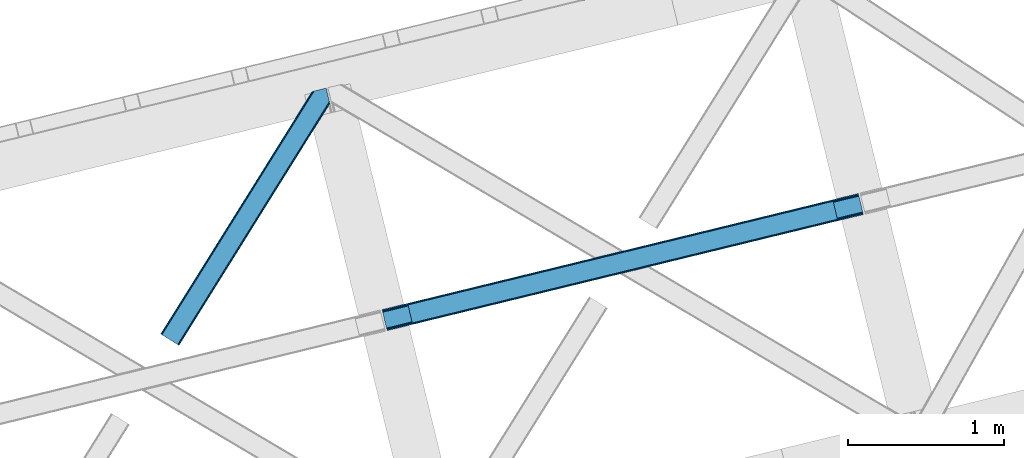
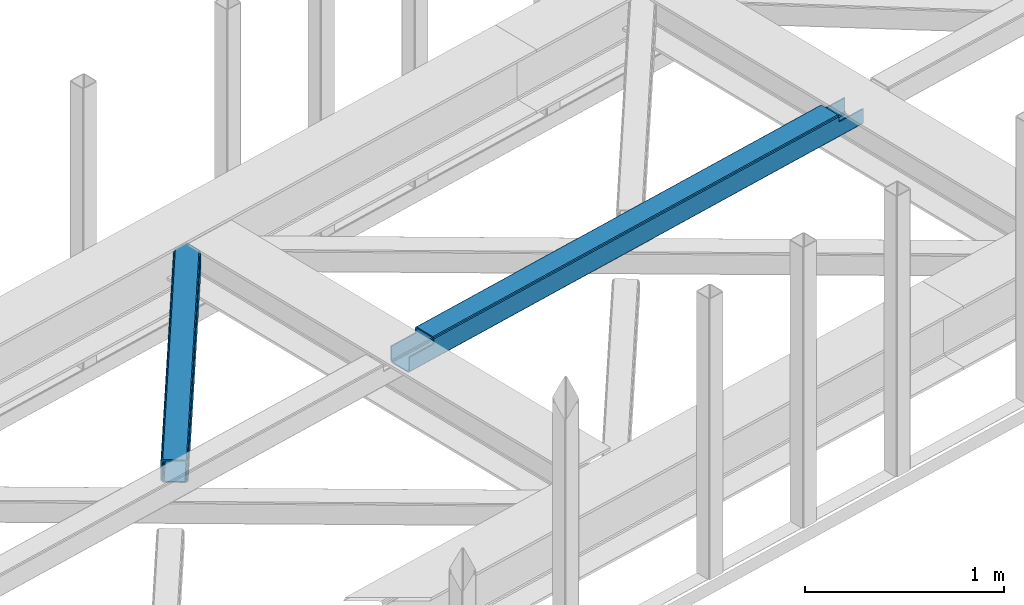
# One storey, part 51 of 66: 1 beam, 1 member.
"""IFC4 building model written with IfcOpenShell, lengths in millimetres."""

from ifc_helpers import new_model, entity, si_unit, converted_unit, derived_unit, direction, frame, origin, place, context, subcontext, project, spatial, triangles, polygons, material, type_object, element, save


model = new_model("IFC4")

# Units and contexts
model_context = context("Model", 3, precision=0.01, world=origin(), true_north=direction((6.12303176911189e-17, 1.0)))
plan_context = context("Plan", 3, precision=0.01, world=origin(), true_north=direction((6.12303176911189e-17, 1.0)))
body_context = subcontext(model_context, "Body", "Model", "MODEL_VIEW")
ifc_project = project(units=[si_unit("LENGTHUNIT", "METRE", prefix="MILLI"), si_unit("AREAUNIT", "SQUARE_METRE"), si_unit("VOLUMEUNIT", "CUBIC_METRE"), converted_unit("PLANEANGLEUNIT", "DEGREE", entity("IfcRatioMeasure", 0.0174532925199433), si_unit("PLANEANGLEUNIT", "RADIAN"), dimensions=[0, 0, 0, 0, 0, 0, 0]), si_unit("MASSUNIT", "GRAM", prefix="KILO"), derived_unit("MASSDENSITYUNIT", [(si_unit("MASSUNIT", "GRAM", prefix="KILO"), 1), (si_unit("LENGTHUNIT", "METRE"), -3)]), derived_unit("MOMENTOFINERTIAUNIT", [(si_unit("LENGTHUNIT", "METRE"), 4)]), si_unit("TIMEUNIT", "SECOND"), si_unit("FREQUENCYUNIT", "HERTZ"), si_unit("THERMODYNAMICTEMPERATUREUNIT", "DEGREE_CELSIUS"), derived_unit("THERMALTRANSMITTANCEUNIT", [(si_unit("MASSUNIT", "GRAM", prefix="KILO"), 1), (si_unit("THERMODYNAMICTEMPERATUREUNIT", "KELVIN"), -1), (si_unit("TIMEUNIT", "SECOND"), -3)]), derived_unit("VOLUMETRICFLOWRATEUNIT", [(si_unit("LENGTHUNIT", "METRE"), 3), (si_unit("TIMEUNIT", "SECOND"), -1)]), derived_unit("MASSFLOWRATEUNIT", [(si_unit("MASSUNIT", "GRAM", prefix="KILO"), 1), (si_unit("TIMEUNIT", "SECOND"), -1)]), derived_unit("ROTATIONALFREQUENCYUNIT", [(si_unit("TIMEUNIT", "SECOND"), -1)]), si_unit("ELECTRICCURRENTUNIT", "AMPERE"), si_unit("ELECTRICVOLTAGEUNIT", "VOLT"), si_unit("POWERUNIT", "WATT"), si_unit("FORCEUNIT", "NEWTON", prefix="KILO"), si_unit("ILLUMINANCEUNIT", "LUX"), si_unit("LUMINOUSFLUXUNIT", "LUMEN"), si_unit("LUMINOUSINTENSITYUNIT", "CANDELA"), derived_unit("USERDEFINED", [(si_unit("MASSUNIT", "GRAM", prefix="KILO"), -1), (si_unit("LENGTHUNIT", "METRE"), -2), (si_unit("TIMEUNIT", "SECOND"), 3), (si_unit("LUMINOUSFLUXUNIT", "LUMEN"), 1)]), derived_unit("LINEARVELOCITYUNIT", [(si_unit("LENGTHUNIT", "METRE"), 1), (si_unit("TIMEUNIT", "SECOND"), -1)]), si_unit("PRESSUREUNIT", "PASCAL"), derived_unit("USERDEFINED", [(si_unit("LENGTHUNIT", "METRE"), -2), (si_unit("MASSUNIT", "GRAM", prefix="KILO"), 1), (si_unit("TIMEUNIT", "SECOND"), -2)]), derived_unit("LINEARFORCEUNIT", [(si_unit("MASSUNIT", "GRAM", prefix="KILO"), 1), (si_unit("LENGTHUNIT", "METRE"), 1), (si_unit("TIMEUNIT", "SECOND"), -2), (si_unit("LENGTHUNIT", "METRE"), -1)]), derived_unit("PLANARFORCEUNIT", [(si_unit("MASSUNIT", "GRAM", prefix="KILO"), 1), (si_unit("LENGTHUNIT", "METRE"), 1), (si_unit("TIMEUNIT", "SECOND"), -2), (si_unit("LENGTHUNIT", "METRE"), -2)])], contexts=[model_context, plan_context])

# Site, building, storey
site_placement = place(None, origin())
site = spatial("IfcSite", under=ifc_project, at=site_placement, CompositionType="ELEMENT")
building_placement = place(site_placement, origin())
building = spatial("IfcBuilding", under=site, at=building_placement, CompositionType="ELEMENT")
storey_placement = place(building_placement, frame((0.0, 0.0, 19800.0)))
storey = spatial("IfcBuildingStorey", under=building, at=storey_placement, Name="06", CompositionType="ELEMENT", Elevation=19800.0)

# Beam
ifc_material = material(Name="Metal painted (White)")
beam_type = type_object("IfcBeamType", PredefinedType="BEAM")
beam_placement = place(storey_placement, frame((-14457.77, 15615.71, 3967.02)))
element("IfcBeam", 1, at=beam_placement, inside=storey, type_object=beam_type, material=ifc_material, ObjectType="Steel Beam", PredefinedType="BEAM", context=body_context, shape_type="Tessellation", body=[
    polygons([(31.1823923917744, 8.09507685196541, 17.8030399336114), (31.4978703677273, 6.80086440699434, 24.4999999999988), (3089.94374939707, 752.329405140575, 24.4999999999988), (3089.62827142111, 753.623617585539, 17.8030399336114), (30.2839871259186, 11.7806820741907, 12.1256313292298), (3088.72986615526, 757.309222807769, 12.1256313292298), (28.9394286278386, 17.2965800886796, 8.33210818105214), (3087.38530765717, 762.825120822256, 8.33210818105214), (27.3534137404056, 23.8030254244704, 7.00000000000274), (3085.79929276974, 769.331566158046, 7.00000000000274), (4.21622439084776, 118.720708051134, 8.33210818105214), (5.80223927828505, 112.214262715345, 7.00000000000274), (3064.24811830762, 857.742803448923, 7.00000000000274), (3062.66210342018, 864.249248784712, 8.33210818105214), (2.8716658927634, 124.236606065622, 12.1256313292342), (3061.3175449221, 869.765146799201, 12.1256313292342), (1.97326062691193, 127.92221128785, 17.8030399336114), (3060.41913965625, 873.450752021428, 17.8030399336114), (1.65778265094818, 129.216423732819, 24.4999999999988), (3060.10366168029, 874.744964466399, 24.4999999999988), (33.1556530186539, 2.16573425859679e-12, 17.5000000000004), (33.1556530186539, 2.16573425859679e-12, 99.499999999999), (31.4978703677187, 6.80086440699001, 99.499999999999), (1.65778265093735, 129.216423732819, 99.499999999999), (6.49720277579036e-12, 136.017288139807, 99.499999999999), (8.66293703438714e-12, 136.017288139807, 17.5000000000004), (0.315477975968082, 134.72307569484, 10.803039933613), (1.21388324181955, 131.037470472612, 5.12563132923143), (2.55844173990175, 125.521572458124, 1.33210818105373), (4.14445662733688, 119.015127122331, 0.0), (29.0111963913235, 17.0021610174783, 0.0), (30.5972112787608, 10.4957156816875, 1.33210818105373), (31.941769776843, 4.97981766719635, 5.12563132923576), (32.8401750426966, 1.29421244496891, 10.803039933613), (3058.44587902936, 881.545828873391, 17.5000000000004), (3058.44587902936, 881.545828873391, 99.499999999999), (3060.10366168029, 874.744964466399, 99.499999999999), (3089.94374939708, 752.329405140575, 99.499999999999), (3091.60153204801, 745.528540733585, 99.499999999999), (3091.60153204801, 745.528540733585, 17.5000000000004), (3091.28605407205, 746.822753178554, 10.803039933613), (3090.3876488062, 750.508358400777, 5.12563132923576), (3089.04309030811, 756.024256415268, 1.33210818105373), (3087.45707542068, 762.530701751058, 0.0), (3062.59033565669, 864.543667855915, 0.0), (3061.00432076926, 871.050113191704, 1.33210818105373), (3059.65976227117, 876.566011206193, 5.12563132923143), (3058.76135700532, 880.251616428422, 10.803039933613), (2925.75994180944, 712.307865540889, 115.5000123926), (2925.81630989431, 712.321604759507, 100.117303289864), (2926.72300362931, 712.542621518195, 99.499999999999), (194.718606580803, 46.5876811586757, 99.5063429816656), (195.631369831908, 46.810141494503, 100.117301735448), (195.69016819362, 46.8244741223611, 115.5), (2928.38078628024, 705.741757111203, 99.499999999999), (2927.47422618801, 705.520772937698, 100.117303484932), (2927.41464342033, 705.506249905358, 122.500007895425), (197.345360928039, 40.0229783796023, 122.500002534479), (197.33858709673, 40.0213271441479, 100.500009163303), (196.748205195731, 39.8773799905087, 99.5697919021647), (2896.88292546721, 834.958147714718, 99.5063429816656), (2895.97381660776, 834.736577552001, 100.117299778624), (2895.91744852289, 834.722838333385, 115.50000888136), (165.850080476841, 169.240033448186, 115.5), (165.840462203334, 169.237688832044, 100.50000941238), (165.250325295043, 169.093836777335, 99.5761204674868), (2894.85332685229, 841.668448882885, 99.5697919021647), (163.220745767771, 175.804071762186, 99.499999999999), (164.133244938508, 176.026503182397, 100.117301984524), (164.189439987617, 176.040201208966, 122.500002796667), (2894.25631754638, 841.522886341469, 122.500003994045), (2894.26642083521, 841.525349756033, 100.500018741102), (2894.56843170077, 840.227853719305, 129.196959150505), (2895.46176722636, 836.541012377613, 134.874360354937), (2896.80305823042, 831.024317672808, 138.667878733795), (2898.38810531643, 824.517636364731, 139.999985502214), (2923.25885436336, 722.50564781542, 139.999991354279), (2924.84634848094, 715.999563150015, 138.667885332354), (2926.19460804138, 710.484567539786, 134.874367586349), (2927.09837274859, 706.800269072834, 129.196966804773), (2925.44675217775, 713.602635936908, 122.196975799125), (2924.54298747053, 717.286934403865, 127.874376580702), (2923.1947279101, 722.801930014085, 131.667894326702), (2921.60723379251, 729.30801467949, 133.000000348631), (2900.05258461851, 817.718404755563, 132.999995276841), (2898.4675375325, 824.225086063638, 131.667888508414), (2897.12624652844, 829.741780768443, 127.874370129564), (2896.23291100285, 833.428622110137, 122.196968925133), (164.878528418706, 169.003207355194, 99.499999999999), (193.131726453727, 57.3201898040377, 131.667891818946), (191.54571156629, 63.8266351398307, 133.0), (194.476284951809, 51.8042917895531, 127.874368670764), (195.374690217663, 48.1186865673257, 122.196960066391), (169.994537104169, 152.237872430709, 133.0), (166.165558452801, 167.945821003215, 122.196960066391), (167.063963718652, 164.260215780989, 127.874368670764), (168.408522216739, 158.7443177665, 131.667891818946), (197.03141194405, 41.3175635421116, 129.196961104604), (196.136488323042, 45.0040174738981, 134.874366301861), (194.794244157291, 50.5204796458708, 138.667887185257), (193.209023953562, 57.0271186991972, 139.999994588639), (168.341882306922, 159.039986838386, 139.999994981919), (166.755021471167, 165.546225960032, 138.667887628704), (165.408105180711, 171.061549222925, 134.874366787843), (164.506189230946, 174.746298656824, 129.196961619)], [[[1, 2, 3, 4]], [[5, 1, 4, 6]], [[7, 5, 6, 8]], [[9, 7, 8, 10]], [[11, 12, 13, 14]], [[15, 11, 14, 16]], [[17, 15, 16, 18]], [[19, 17, 18, 20]], [[12, 9, 10, 13]], [[21, 22, 23, 2, 1, 5, 7, 9, 12, 11, 15, 17, 19, 24, 25, 26, 27, 28, 29, 30, 31, 32, 33, 34]], [[35, 36, 37, 20, 18, 16, 14, 13, 10, 8, 6, 4, 3, 38, 39, 40, 41, 42, 43, 44, 45, 46, 47, 48]], [[49, 50, 51, 38, 3, 2, 23, 52, 53, 54]], [[55, 39, 38, 51]], [[39, 55, 56, 57, 58, 59, 60, 22, 21, 40]], [[32, 31, 44, 43]], [[33, 32, 43, 42]], [[34, 33, 42, 41]], [[21, 34, 41, 40]], [[31, 30, 45, 44]], [[27, 26, 35, 48]], [[28, 27, 48, 47]], [[29, 28, 47, 46]], [[30, 29, 46, 45]], [[20, 37, 61, 62, 63, 64, 65, 66, 24, 19]], [[67, 36, 35, 26, 25, 68, 69, 70, 71, 72]], [[36, 67, 61, 37]], [[72, 71, 73, 74, 75, 76, 77, 78, 79, 80, 57, 56, 50, 49, 81, 82, 83, 84, 85, 86, 87, 88, 63, 62]], [[60, 52, 23, 22]], [[25, 24, 89, 68]], [[90, 91, 84, 83]], [[92, 90, 83, 82]], [[93, 92, 82, 81]], [[54, 93, 81, 49]], [[94, 85, 84, 91]], [[95, 64, 63, 88]], [[96, 95, 88, 87]], [[97, 96, 87, 86]], [[94, 97, 86, 85]], [[65, 64, 95, 96, 97, 94, 91, 90, 92, 93, 54, 53, 59, 58, 98, 99, 100, 101, 102, 103, 104, 105, 70, 69]], [[98, 58, 57, 80]], [[99, 98, 80, 79]], [[100, 99, 79, 78]], [[101, 100, 78, 77]], [[77, 76, 102, 101]], [[103, 102, 76, 75]], [[104, 103, 75, 74]], [[105, 104, 74, 73]], [[70, 105, 73, 71]]], closed=False),
])

# Member
member_type = type_object("IfcMemberType", PredefinedType="BRACE")
member_placement = place(storey_placement, frame((-15879.74, 15520.97, 3823.0)))
element("IfcMember", 2, at=member_placement, inside=storey, type_object=member_type, ObjectType="Steel Horizontal Brace", PredefinedType="BRACE", context=body_context, shape_type="Tessellation", body=[
    triangles([(933.020956420898, 1535.69230957031, 0.0), (967.780462646484, 1393.09287414551, 0.0), (14.8444427490231, 64.8704589843746, 0.0), (103.914587402343, 9.2680389404286, 0.0), (928.803771972656, 1552.99241638184, 5.49966430664063), (928.943298339844, 1552.41687011719, 5.208984375), (930.803649902344, 1544.78826599121, 1.33247680664135), (971.997647094726, 1375.79393005371, 5.49966430664063), (971.856958007813, 1376.36831359863, 5.208984375), (969.997769165038, 1383.99808044434, 1.33247680664135), (972.208099365234, 1375.53813171387, 5.8531311035149), (972.423202514648, 1375.28349609375, 6.20659790039281), (928.911904907227, 1553.57028808594, 5.74383544921875), (972.725509643555, 1375.53929443359, 6.35310058593677), (929.027014160156, 1554.1772277832, 5.9996337890625), (973.026654052734, 1375.79393005371, 6.49960327148438), (929.142123413085, 1554.78416748047, 6.25543212890625), (929.254907226563, 1555.3632019043, 6.49960327148438), (4.34857177734375, 71.4235473632798, 5.12526855468968), (1.13016357421839, 73.4315643310547, 10.8039916992202), (973.360354614257, 1630.84347839356, 10.8039916992202), (976.915951538085, 1631.71086730957, 6.49960327148438), (9.16455688476526, 68.4167541503903, 1.33247680664135), (971.508142089844, 1630.39234313965, 17.5012573242202), (0.0, 74.1373352050778, 17.5012573242202), (1081.10145263672, 1548.91824645996, 6.49960327148438), (1056.20878601074, 1651.03875732422, 6.49960327148438), (971.508142089844, 1630.39234313965, 122.499499511719), (0.0, 74.1373352050778, 122.499499511719), (973.360354614257, 1630.84347839356, 129.196765136719), (1.13016357421839, 73.4315643310547, 129.196765136719), (978.633288574218, 1632.12944641113, 134.87548828125), (4.34857177734375, 71.4235473632798, 134.87548828125), (986.526992797852, 1634.05374755859, 138.668280029298), (9.16455688476526, 68.4167541503903, 138.668280029298), (995.840377807617, 1636.32337646484, 140.00075683594), (14.8444427490231, 64.8704589843746, 140.00075683594), (118.757867431641, 0.0, 17.5012573242202), (117.628866577148, 0.705770874023074, 10.8039916992202), (1085.14190368652, 1551.25182495117, 10.9783996582046), (1087.41734619141, 1552.56569824219, 13.4991760253906), (109.594473266601, 5.72174377441297, 1.33247680664135), (114.410458374023, 2.71495056152344, 5.12526855468968), (1087.56966247559, 1551.93550415039, 17.5012573242202), (1081.77699279785, 1575.70265808105, 140.00075683594), (1063.00837097168, 1652.6967956543, 140.00075683594), (103.914587402343, 9.2680389404286, 140.00075683594), (1083.99429931641, 1566.60786437988, 138.668280029298), (109.594473266601, 5.72174377441297, 138.668280029298), (1085.87325439453, 1558.89670715332, 134.87548828125), (114.410458374023, 2.71495056152344, 134.87548828125), (1087.12899169922, 1553.74469604492, 129.196765136719), (117.628866577148, 0.705770874023074, 129.196765136719), (1087.56966247559, 1551.93550415039, 122.499499511719), (118.757867431641, 0.0, 122.499499511719), (1082.5362487793, 1566.77413330078, 12.1248413085959), (1083.96523132324, 1566.72529907227, 13.4991760253906), (1077.85165100098, 1569.98672790527, 8.3320495605476), (1074.64603271484, 1577.50138549805, 6.99957275390625), (1056.69131469727, 1651.1561920166, 6.99957275390625), (1005.57350463867, 1638.69648742676, 6.99957275390625), (20.7836151123047, 61.163708496093, 6.99957275390625), (97.9789031982418, 12.9759521484375, 6.99957275390625), (108.475936889648, 6.42286376953052, 12.1248413085959), (111.694345092774, 4.41368408203016, 17.8035644531265), (1084.81169128418, 1563.25225524902, 17.8035644531265), (103.659951782227, 9.42849426269458, 8.3320495605476), (1085.25236206055, 1561.44306335449, 24.5008300781265), (112.823345947265, 3.70791320800708, 24.5008300781265), (983.093481445312, 1633.21658935547, 17.8035644531265), (981.241268920898, 1632.76429138183, 24.5008300781265), (7.0693359375, 69.7248138427731, 17.8035644531265), (5.94033508300708, 70.4305847167961, 24.5008300781265), (988.366415405273, 1634.50139465332, 12.1248413085959), (10.2877441406254, 67.716796875, 12.1248413085959), (996.260119628905, 1636.42569580078, 8.3320495605476), (15.1037292480469, 64.7100036621086, 8.3320495605476), (981.241268920898, 1632.76429138183, 115.499926757813), (5.94033508300708, 70.4305847167961, 115.499926757813), (996.260119628905, 1636.42569580078, 131.668707275392), (1005.57350463867, 1638.69648742676, 133.001184082033), (1063.00837097168, 1652.6967956543, 133.001184082033), (988.366415405273, 1634.50139465332, 127.873590087893), (983.093481445312, 1633.21658935547, 122.197192382813), (20.7836151123047, 61.163708496093, 133.001184082033), (15.1037292480469, 64.7100036621086, 131.668707275392), (10.2877441406254, 67.716796875, 127.873590087893), (7.0693359375, 69.7248138427731, 122.197192382813), (108.475936889648, 6.42286376953052, 127.873590087893), (111.694345092774, 4.41368408203016, 122.197192382813), (112.823345947265, 3.70791320800708, 115.499926757813), (97.9789031982418, 12.9759521484375, 133.001184082033), (103.659951782227, 9.42849426269458, 131.668707275392), (1085.25236206055, 1561.44306335449, 115.499926757813), (1084.81169128418, 1563.25225524902, 122.197192382813), (1083.55595397949, 1568.40426635742, 127.873590087893), (1081.67699890137, 1576.11426086426, 131.668707275392), (1079.45969238281, 1585.20905456543, 133.001184082033)], [[1, 2, 3], [4, 3, 2], [1, 5, 2], [6, 5, 1], [1, 7, 6], [2, 5, 8], [8, 9, 2], [10, 2, 9], [11, 8, 5], [12, 11, 13], [14, 12, 15], [16, 14, 17], [17, 18, 16], [15, 17, 14], [13, 15, 12], [5, 13, 11], [17, 19, 18], [19, 17, 15], [13, 19, 15], [19, 13, 5], [5, 6, 19], [20, 21, 18], [18, 19, 20], [21, 22, 18], [19, 6, 7], [7, 1, 23], [3, 23, 1], [7, 23, 19], [24, 21, 20], [20, 25, 24], [18, 26, 16], [26, 18, 22], [27, 26, 22], [28, 24, 25], [25, 29, 28], [30, 28, 31], [29, 31, 28], [32, 30, 33], [31, 33, 30], [34, 32, 35], [33, 35, 32], [36, 34, 37], [35, 37, 34], [38, 39, 40], [40, 41, 38], [42, 10, 9], [39, 12, 16], [16, 40, 39], [16, 26, 40], [9, 39, 43], [9, 12, 39], [9, 43, 42], [2, 10, 4], [42, 4, 10], [41, 44, 38], [45, 36, 37], [36, 45, 46], [37, 47, 45], [48, 45, 47], [47, 49, 48], [50, 48, 49], [49, 51, 50], [52, 50, 51], [51, 53, 52], [54, 52, 53], [53, 55, 54], [44, 54, 38], [55, 38, 54], [56, 40, 26], [41, 40, 56], [56, 57, 41], [58, 26, 59], [26, 58, 56], [60, 59, 26], [59, 61, 62], [61, 59, 60], [62, 63, 59], [64, 65, 66], [66, 57, 64], [58, 59, 63], [63, 67, 58], [56, 58, 67], [67, 64, 56], [57, 56, 64], [68, 66, 65], [65, 69, 68], [70, 71, 72], [73, 72, 71], [74, 70, 75], [72, 75, 70], [76, 74, 77], [75, 77, 74], [61, 76, 62], [77, 62, 76], [71, 78, 79], [79, 73, 71], [34, 36, 80], [46, 81, 36], [81, 46, 82], [81, 80, 36], [83, 34, 80], [83, 32, 34], [32, 84, 30], [84, 32, 83], [28, 84, 78], [84, 28, 30], [61, 22, 76], [70, 74, 22], [74, 76, 22], [61, 60, 22], [71, 70, 24], [21, 24, 70], [28, 71, 24], [71, 28, 78], [70, 22, 21], [80, 81, 85], [85, 86, 80], [83, 80, 86], [86, 87, 83], [84, 83, 87], [87, 88, 84], [78, 84, 88], [88, 79, 78], [53, 89, 90], [91, 38, 55], [53, 90, 55], [53, 51, 89], [90, 91, 55], [89, 51, 49], [92, 47, 37], [47, 93, 49], [93, 47, 92], [93, 89, 49], [39, 64, 43], [69, 38, 91], [38, 65, 39], [65, 38, 69], [39, 65, 64], [4, 63, 3], [42, 43, 64], [64, 67, 42], [67, 63, 4], [4, 42, 67], [87, 35, 33], [37, 85, 92], [37, 86, 85], [86, 37, 35], [87, 86, 35], [79, 29, 25], [31, 88, 87], [33, 31, 87], [88, 31, 29], [79, 88, 29], [23, 75, 19], [3, 63, 62], [62, 77, 3], [77, 75, 23], [23, 3, 77], [20, 19, 75], [25, 73, 79], [72, 25, 20], [25, 72, 73], [72, 20, 75], [66, 41, 57], [54, 44, 68], [44, 66, 68], [68, 94, 54], [44, 41, 66], [95, 54, 94], [52, 54, 95], [50, 95, 96], [95, 50, 52], [96, 48, 50], [97, 48, 96], [97, 98, 45], [97, 45, 48], [98, 46, 45], [98, 82, 46], [81, 98, 85], [81, 82, 98], [92, 85, 98], [95, 94, 90], [91, 90, 94], [96, 95, 89], [90, 89, 95], [97, 96, 93], [89, 93, 96], [98, 97, 92], [93, 92, 97], [94, 68, 69], [69, 91, 94]]),
])

save(model, "model.ifc")
